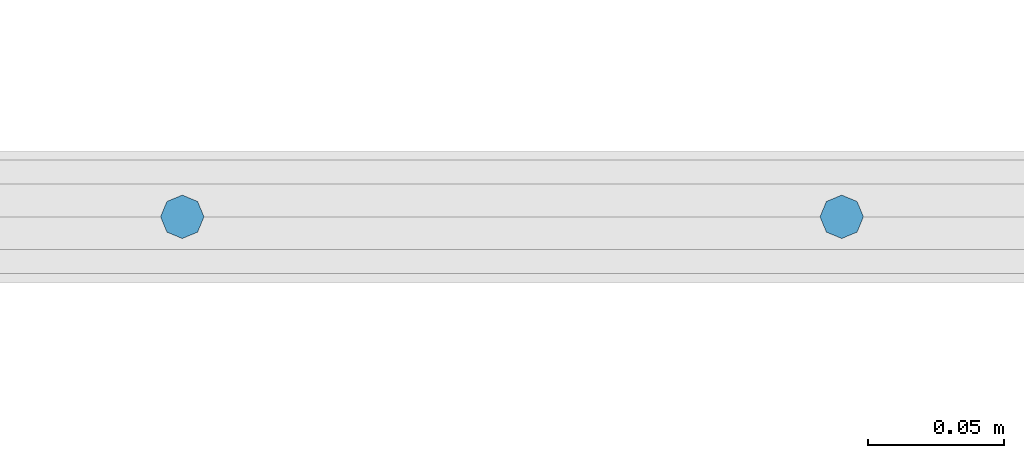
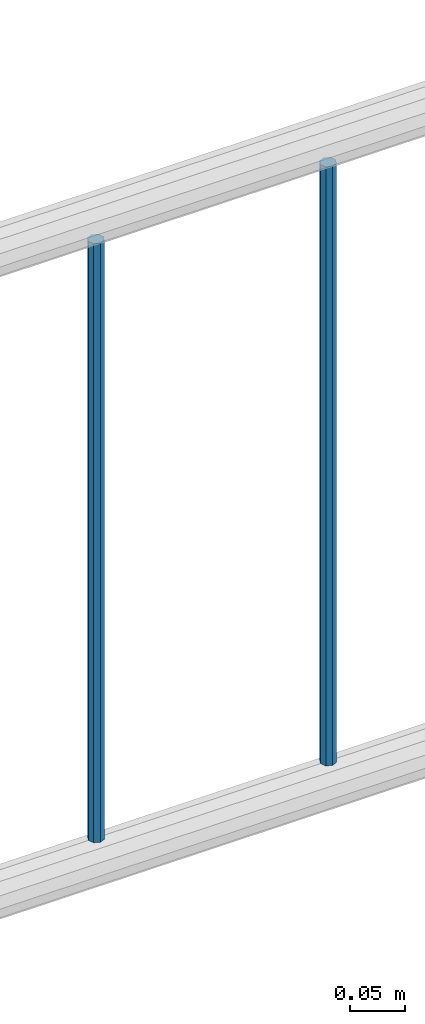
# One storey, part 99 of 270: 2 columns.
"""IFC2X3 building model written with IfcOpenShell, lengths in millimetres."""

from ifc_helpers import new_model, si_unit, frame, origin_with_axes, place, context, subcontext, project, spatial, faceted_brep, material, type_object, element, save


model = new_model("IFC2X3")

# Units and contexts
model_context = context("Model", 3, precision=1e-05, world=origin_with_axes())
body_context = subcontext(model_context, "Body", "Model", "MODEL_VIEW")
ifc_project = project(units=[si_unit("LENGTHUNIT", "METRE", prefix="MILLI"), si_unit("AREAUNIT", "SQUARE_METRE"), si_unit("VOLUMEUNIT", "CUBIC_METRE"), si_unit("MASSUNIT", "GRAM", prefix="KILO"), si_unit("TIMEUNIT", "SECOND"), si_unit("PLANEANGLEUNIT", "RADIAN"), si_unit("SOLIDANGLEUNIT", "STERADIAN"), si_unit("THERMODYNAMICTEMPERATUREUNIT", "DEGREE_CELSIUS"), si_unit("LUMINOUSINTENSITYUNIT", "LUMEN")], contexts=[model_context])

# Site, building, storey
site_placement = place(None, origin_with_axes())
site = spatial("IfcSite", under=ifc_project, at=site_placement, CompositionType="ELEMENT")
building_placement = place(site_placement, origin_with_axes())
building = spatial("IfcBuilding", under=site, at=building_placement, Name="Standard", CompositionType="ELEMENT")
storey_placement = place(building_placement, origin_with_axes())
storey = spatial("IfcBuildingStorey", under=building, at=storey_placement, Name="Undefined", CompositionType="ELEMENT", Elevation=0.0)

# Columns
ifc_material = material(Name="STEEL/S355J2")
column_type = type_object("IfcColumnType", Name="D16", PredefinedType="NOTDEFINED")
for number, where, z_axis, x_axis in (
    (1, (30729.0960237801, -18058.1460000038, 248.800000000007), (-1.0, 0.0, 0.0), (0.0, 0.0, 1.0)),
    (2, (30972.0960237801, -18058.1460000038, 248.800000000007), (-1.0, 0.0, 0.0), (0.0, 0.0, 1.0)),
):
    element("IfcColumn", number, at=place(storey_placement, frame(where, z_axis=z_axis, x_axis=x_axis)), inside=storey, type_object=column_type, material=ifc_material, ObjectType="D16", context=body_context, shape_type="Brep", body=[
        faceted_brep([(0.0, -8.0, 0.0), (0.0, -5.65685424949334, -5.65685424949334), (663.0, -5.65685424949334, -5.65685424949334), (663.0, -8.0, 0.0), (0.0, 0.0, -8.0), (663.0, 0.0, -8.0), (0.0, 5.65685424949334, -5.65685424949334), (663.0, 5.65685424949334, -5.65685424949334), (0.0, 8.0, 0.0), (663.0, 8.0, 0.0), (0.0, 5.65685424949334, 5.65685424949334), (663.0, 5.65685424949334, 5.65685424949334), (0.0, 0.0, 8.0), (663.0, 0.0, 8.0), (0.0, -5.65685424949334, 5.65685424949334), (663.0, -5.65685424949334, 5.65685424949334)], [[[0, 1, 2, 3]], [[1, 4, 5, 2]], [[4, 6, 7, 5]], [[6, 8, 9, 7]], [[8, 10, 11, 9]], [[10, 12, 13, 11]], [[12, 14, 15, 13]], [[14, 0, 3, 15]], [[5, 7, 9, 11, 13, 15, 3, 2]], [[14, 12, 10, 8, 6, 4, 1, 0]]]),
    ])

save(model, "model.ifc")
